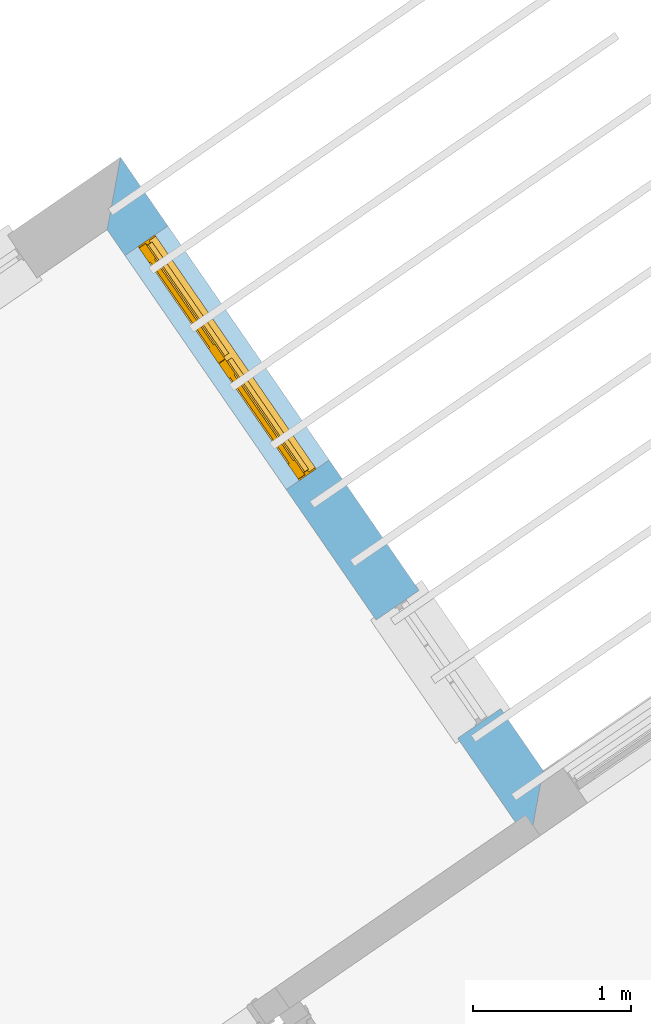
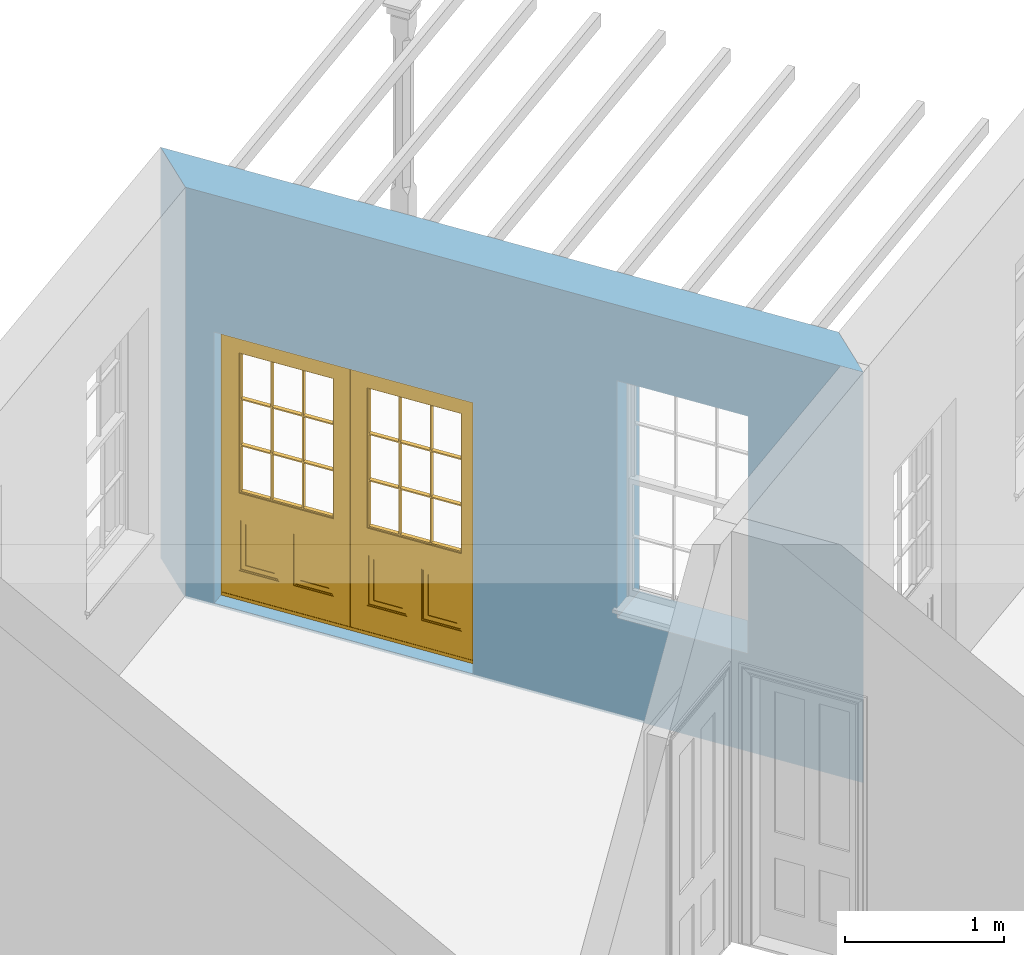
# One storey, part 8 of 12: 1 door, 2 openings, plus 1 element that does not belong to this part.
"""IFC2X3 building model written with IfcOpenShell, lengths in metres."""

from ifc_helpers import new_model, si_unit, frame, origin, place, context, subcontext, project, spatial, polyline, outline, extrude, faceted_brep, material, layer, layer_set, layer_usage, element, fill, save


model = new_model("IFC2X3")

# Units and contexts
model_context = context("Model", 3, world=origin())
body_context = subcontext(model_context, "Body", "Model", "MODEL_VIEW")
ifc_project = project(units=[si_unit("PLANEANGLEUNIT", "RADIAN"), si_unit("MASSUNIT", "GRAM", prefix="KILO"), si_unit("FORCEUNIT", "NEWTON", prefix="KILO"), si_unit("LENGTHUNIT", "METRE")], contexts=[model_context])

# Site, building, storey
site_placement = place(None, origin())
site = spatial("IfcSite", under=ifc_project, at=site_placement, CompositionType="ELEMENT")
building_placement = place(None, origin())
building = spatial("IfcBuilding", under=site, at=building_placement, Name="Building plot-7", CompositionType="ELEMENT")
storey_placement = place(None, frame((0.0, 0.0, 8.0)))
storey = spatial("IfcBuildingStorey", under=building, at=storey_placement, Name="Floor 1", CompositionType="ELEMENT", Elevation=8.0)

# Wall, openings, door
ifc_material = material(Name="Masonry")
ifc_layer = layer(ifc_material, 0.33, ventilated=False)
ifc_layer_set = layer_set([ifc_layer], Name="My Wall")
ifc_layer_usage = layer_usage(ifc_layer_set, "AXIS2", "NEGATIVE", 0.08)
wall_placement = place(storey_placement, origin())
wall = element("IfcWallStandardCase", 1, at=wall_placement, inside=storey, material=ifc_layer_usage, Name="exterior", context=body_context, shape_type="SweptSolid", body=[
    extrude(outline(polyline([(88.1099803913297, 67.5367543573869), (88.1944908209502, 67.9957292883857), (85.5190596071891, 71.8787614387522), (85.4345491775686, 71.4197865077534), (88.1099803913297, 67.5367543573869)])), origin(), (0.0, 0.0, 1.0), 3.15),
])
opening_1_placement = place(storey_placement, frame((0.0, 0.0, 0.75)))
element("IfcOpeningElement", 2, at=opening_1_placement, cuts=wall, Name="Opening", ObjectType="Opening", context=body_context, shape_type="SweptSolid", body=[
    extrude(outline(polyline([(87.9256291894368, 68.3859461453158), (87.4093220739, 69.1352971728363), (87.1375793935903, 68.9480649221472), (87.6538865091271, 68.1987138946266), (87.9256291894368, 68.3859461453158)])), origin(), (0.0, 0.0, 1.0), 1.82),
])
opening_2_placement = place(storey_placement, frame((0.0, 0.0, 0.0199999999999996)))
opening_2 = element("IfcOpeningElement", 3, at=opening_2_placement, cuts=wall, Name="Opening", ObjectType="Opening", context=body_context, shape_type="SweptSolid", body=[
    extrude(outline(polyline([(86.8403934357583, 69.9610213334149), (85.8191266138174, 71.4432541351038), (85.5473839335077, 71.2560218844146), (86.5686507554486, 69.7737890827257), (86.8403934357583, 69.9610213334149)])), origin(), (0.0, 0.0, 1.0), 2.08),
])
door_placement = place(storey_placement, frame((86.634527768857, 69.8191787192564, 0.0199999999999996), z_axis=(0.0, 0.0, 1.0), x_axis=(-1.02126682194091, 1.48223280168895, 0.0)))
door = element("IfcDoor", 4, at=door_placement, inside=storey, Name="living outside door", OverallHeight=2.08, OverallWidth=1.8, context=body_context, shape_type="Brep", held_by="IfcProductRepresentation", body=[
    faceted_brep([(0.545, -0.055, 0.265), (0.745, -0.055, 0.265), (0.745, -0.05, 0.265), (0.545, -0.05, 0.265), (0.745, -0.05, 0.58), (0.545, -0.05, 0.58), (0.545, -0.055, 0.58), (0.515, -0.06, 0.235), (0.775, -0.06, 0.235), (0.745, -0.055, 0.58), (0.515, -0.06, 0.61), (0.515, -0.065, 0.235), (0.775, -0.065, 0.235), (0.775, -0.06, 0.61), (0.515, -0.065, 0.61), (0.785, -0.065, 0.225), (0.505, -0.065, 0.225), (0.775, -0.065, 0.61), (0.505, -0.065, 0.62), (0.785, -0.065, 0.62), (0.505, -0.07, 0.225), (0.785, -0.07, 0.225), (0.505, -0.07, 0.62), (0.785, -0.07, 0.62), (0.883, -0.07, 0.075), (0.898, -0.07, 0.075), (0.405, -0.07, 0.62), (0.405, -0.07, 0.225), (0.027, -0.07, 0.075), (0.785, -0.07, 0.82), (0.125, -0.07, 0.82), (0.405, -0.065, 0.62), (0.405, -0.065, 0.225), (0.898, -0.07, 2.068), (0.027, -0.08, 0.075), (0.883, -0.08, 0.075), (0.125, -0.07, 0.225), (0.012, -0.07, 0.075), (0.785, -0.06, 0.82), (0.125, -0.06, 0.82), (0.125, -0.07, 0.62), (0.125, -0.065, 0.62), (0.395, -0.065, 0.61), (0.395, -0.065, 0.235), (0.125, -0.065, 0.225), (0.785, -0.07, 1.895), (0.027, -0.11, 0.045), (0.883, -0.11, 0.045), (0.558333, -0.06, 0.83), (0.351667, -0.06, 0.83), (0.125, -0.07, 1.895), (0.125, -0.06, 1.895), (0.785, -0.06, 1.895), (0.012, -0.07, 2.068), (0.135, -0.065, 0.61), (0.395, -0.06, 0.61), (0.395, -0.06, 0.235), (0.135, -0.065, 0.235), (0.027, -0.11, 0.027), (0.883, -0.11, 0.027), (0.568333, -0.06, 0.83), (0.558333, -0.03, 0.83), (0.351667, -0.03, 0.83), (0.341667, -0.06, 0.83), (0.135, -0.06, 1.185), (0.135, -0.06, 1.53), (0.775, -0.06, 1.53), (0.775, -0.06, 1.185), (0.135, -0.06, 0.61), (0.365, -0.055, 0.58), (0.365, -0.055, 0.265), (0.135, -0.06, 0.235), (0.568333, -0.06, 1.175), (0.558333, -0.06, 1.175), (0.775, -0.06, 0.83), (0.558333, -0.03, 1.175), (0.785, -0.03, 0.82), (0.125, -0.03, 0.82), (0.351667, -0.03, 1.175), (0.351667, -0.06, 1.175), (0.341667, -0.06, 1.175), (0.135, -0.06, 0.83), (0.135, -0.06, 1.175), (0.135, -0.03, 1.185), (0.135, -0.03, 1.53), (0.135, -0.06, 1.54), (0.351667, -0.06, 1.885), (0.558333, -0.06, 1.885), (0.775, -0.03, 1.53), (0.775, -0.03, 1.185), (0.775, -0.06, 1.175), (0.775, -0.06, 1.54), (0.165, -0.055, 0.58), (0.365, -0.05, 0.58), (0.365, -0.05, 0.265), (0.165, -0.055, 0.265), (0.568333, -0.03, 0.83), (0.568333, -0.03, 1.175), (0.568333, -0.06, 1.185), (0.558333, -0.06, 1.185), (0.775, -0.03, 0.83), (0.785, -0.02, 0.82), (0.125, -0.02, 0.82), (0.341667, -0.03, 0.83), (0.341667, -0.03, 1.175), (0.351667, -0.06, 1.185), (0.341667, -0.06, 1.185), (0.135, -0.03, 0.83), (0.341667, -0.03, 1.185), (0.125, -0.03, 1.895), (0.341667, -0.03, 1.53), (0.341667, -0.06, 1.53), (0.135, -0.06, 1.885), (0.341667, -0.06, 1.54), (0.341667, -0.06, 1.885), (0.558333, -0.03, 1.885), (0.351667, -0.03, 1.885), (0.568333, -0.06, 1.885), (0.785, -0.03, 1.895), (0.568333, -0.03, 1.185), (0.568333, -0.06, 1.53), (0.568333, -0.03, 1.53), (0.568333, -0.06, 1.54), (0.775, -0.06, 1.885), (0.165, -0.05, 0.58), (0.165, -0.05, 0.265), (0.775, -0.03, 1.175), (0.558333, -0.06, 1.53), (0.351667, -0.03, 1.185), (0.558333, -0.03, 1.185), (0.505, -0.02, 0.62), (0.405, -0.02, 0.62), (0.125, -0.02, 1.895), (0.785, -0.02, 1.895), (0.351667, -0.06, 1.53), (0.135, -0.03, 1.175), (0.135, -0.03, 1.54), (0.341667, -0.03, 1.54), (0.135, -0.03, 1.885), (0.351667, -0.06, 1.54), (0.558333, -0.03, 1.54), (0.558333, -0.06, 1.54), (0.351667, -0.03, 1.54), (0.775, -0.03, 1.54), (0.568333, -0.03, 1.54), (0.775, -0.03, 1.885), (0.558333, -0.03, 1.53), (0.405, -0.02, 0.225), (0.505, -0.02, 0.225), (0.125, -0.02, 0.62), (0.785, -0.02, 0.62), (0.012, -0.02, 2.068), (0.898, -0.02, 2.068), (0.351667, -0.03, 1.53), (0.341667, -0.03, 1.885), (0.568333, -0.03, 1.885), (0.405, -0.025, 0.225), (0.405, -0.025, 0.62), (0.505, -0.025, 0.62), (0.505, -0.025, 0.225), (0.898, -0.02, 0.027), (0.012, -0.02, 0.027), (0.125, -0.025, 0.62), (0.785, -0.025, 0.62), (0.395, -0.025, 0.235), (0.395, -0.025, 0.61), (0.125, -0.02, 0.225), (0.125, -0.025, 0.225), (0.515, -0.025, 0.61), (0.515, -0.025, 0.235), (0.785, -0.02, 0.225), (0.785, -0.025, 0.225), (0.135, -0.025, 0.61), (0.775, -0.025, 0.61), (0.135, -0.025, 0.235), (0.395, -0.03, 0.235), (0.395, -0.03, 0.61), (0.515, -0.03, 0.61), (0.515, -0.03, 0.235), (0.775, -0.025, 0.235), (0.135, -0.03, 0.61), (0.775, -0.03, 0.61), (0.135, -0.03, 0.235), (0.365, -0.035, 0.265), (0.365, -0.035, 0.58), (0.545, -0.035, 0.58), (0.545, -0.035, 0.265), (0.775, -0.03, 0.235), (0.165, -0.035, 0.58), (0.745, -0.035, 0.58), (0.165, -0.035, 0.265), (0.365, -0.04, 0.58), (0.365, -0.04, 0.265), (0.545, -0.04, 0.58), (0.545, -0.04, 0.265), (0.745, -0.035, 0.265), (0.165, -0.04, 0.58), (0.745, -0.04, 0.58), (0.165, -0.04, 0.265), (0.745, -0.04, 0.265), (1.775, -0.072, 0.025), (0.025, -0.072, 0.025), (0.025, -0.1, 0.025), (1.775, -0.1, 0.025), (1.79, -0.02, 0.025), (0.01, -0.02, 0.025), (1.79, -0.072, 0.025), (1.8, -0.02, 0.0), (0.0, -0.02, 0.0), (0.01, -0.072, 0.025), (1.79, -0.072, 2.07), (1.79, -0.02, 2.07), (1.775, -0.072, 2.055), (1.8, -0.02, 2.08), (0.01, -0.02, 2.07), (0.0, -0.02, 2.08), (0.01, -0.072, 2.07), (0.025, -0.072, 2.055), (0.0, -0.15, 2.08), (1.8, -0.15, 2.08), (0.01, -0.15, 2.07), (1.79, -0.15, 2.07), (0.01, -0.1, 2.07), (1.79, -0.1, 2.07), (0.0, -0.15, 0.0), (1.8, -0.15, 0.0), (0.01, -0.15, 0.025), (1.79, -0.15, 0.025), (0.01, -0.1, 0.025), (0.025, -0.1, 2.055), (1.79, -0.1, 0.025), (1.775, -0.1, 2.055), (0.898, -0.07, 0.027), (0.012, -0.07, 0.027), (0.883, -0.07, 0.027), (0.027, -0.07, 0.027), (1.435, -0.055, 0.265), (1.635, -0.055, 0.265), (1.635, -0.05, 0.265), (1.435, -0.05, 0.265), (1.635, -0.05, 0.58), (1.435, -0.05, 0.58), (1.435, -0.055, 0.58), (1.405, -0.06, 0.235), (1.665, -0.06, 0.235), (1.635, -0.055, 0.58), (1.405, -0.06, 0.61), (1.405, -0.065, 0.235), (1.665, -0.065, 0.235), (1.665, -0.06, 0.61), (1.405, -0.065, 0.61), (1.675, -0.065, 0.225), (1.395, -0.065, 0.225), (1.665, -0.065, 0.61), (1.395, -0.065, 0.62), (1.675, -0.065, 0.62), (1.395, -0.07, 0.225), (1.675, -0.07, 0.225), (1.395, -0.07, 0.62), (1.675, -0.07, 0.62), (1.773, -0.07, 0.075), (1.788, -0.07, 0.075), (1.295, -0.07, 0.62), (1.295, -0.07, 0.225), (0.917, -0.07, 0.075), (1.675, -0.07, 0.82), (1.015, -0.07, 0.82), (1.295, -0.065, 0.62), (1.295, -0.065, 0.225), (1.788, -0.07, 2.068), (0.917, -0.08, 0.075), (1.773, -0.08, 0.075), (1.015, -0.07, 0.225), (0.902, -0.07, 0.075), (1.675, -0.06, 0.82), (1.015, -0.06, 0.82), (1.015, -0.07, 0.62), (1.015, -0.065, 0.62), (1.285, -0.065, 0.61), (1.285, -0.065, 0.235), (1.015, -0.065, 0.225), (1.675, -0.07, 1.895), (0.917, -0.11, 0.045), (1.773, -0.11, 0.045), (1.448333, -0.06, 0.83), (1.241667, -0.06, 0.83), (1.015, -0.07, 1.895), (1.015, -0.06, 1.895), (1.675, -0.06, 1.895), (0.902, -0.07, 2.068), (1.025, -0.065, 0.61), (1.285, -0.06, 0.61), (1.285, -0.06, 0.235), (1.025, -0.065, 0.235), (0.917, -0.11, 0.027), (1.773, -0.11, 0.027), (1.458333, -0.06, 0.83), (1.448333, -0.03, 0.83), (1.241667, -0.03, 0.83), (1.231667, -0.06, 0.83), (1.025, -0.06, 1.185), (1.025, -0.06, 1.53), (1.665, -0.06, 1.53), (1.665, -0.06, 1.185), (1.025, -0.06, 0.61), (1.255, -0.055, 0.58), (1.255, -0.055, 0.265), (1.025, -0.06, 0.235), (1.458333, -0.06, 1.175), (1.448333, -0.06, 1.175), (1.665, -0.06, 0.83), (1.448333, -0.03, 1.175), (1.675, -0.03, 0.82), (1.015, -0.03, 0.82), (1.241667, -0.03, 1.175), (1.241667, -0.06, 1.175), (1.231667, -0.06, 1.175), (1.025, -0.06, 0.83), (1.025, -0.06, 1.175), (1.025, -0.03, 1.185), (1.025, -0.03, 1.53), (1.025, -0.06, 1.54), (1.241667, -0.06, 1.885), (1.448333, -0.06, 1.885), (1.665, -0.03, 1.53), (1.665, -0.03, 1.185), (1.665, -0.06, 1.175), (1.665, -0.06, 1.54), (1.055, -0.055, 0.58), (1.255, -0.05, 0.58), (1.255, -0.05, 0.265), (1.055, -0.055, 0.265), (1.458333, -0.03, 0.83), (1.458333, -0.03, 1.175), (1.458333, -0.06, 1.185), (1.448333, -0.06, 1.185), (1.665, -0.03, 0.83), (1.675, -0.02, 0.82), (1.015, -0.02, 0.82), (1.231667, -0.03, 0.83), (1.231667, -0.03, 1.175), (1.241667, -0.06, 1.185), (1.231667, -0.06, 1.185), (1.025, -0.03, 0.83), (1.231667, -0.03, 1.185), (1.015, -0.03, 1.895), (1.231667, -0.03, 1.53), (1.231667, -0.06, 1.53), (1.025, -0.06, 1.885), (1.231667, -0.06, 1.54), (1.231667, -0.06, 1.885), (1.448333, -0.03, 1.885), (1.241667, -0.03, 1.885), (1.458333, -0.06, 1.885), (1.675, -0.03, 1.895), (1.458333, -0.03, 1.185), (1.458333, -0.06, 1.53), (1.458333, -0.03, 1.53), (1.458333, -0.06, 1.54), (1.665, -0.06, 1.885), (1.055, -0.05, 0.58), (1.055, -0.05, 0.265), (1.665, -0.03, 1.175), (1.448333, -0.06, 1.53), (1.241667, -0.03, 1.185), (1.448333, -0.03, 1.185), (1.395, -0.02, 0.62), (1.295, -0.02, 0.62), (1.015, -0.02, 1.895), (1.675, -0.02, 1.895), (1.241667, -0.06, 1.53), (1.025, -0.03, 1.175), (1.025, -0.03, 1.54), (1.231667, -0.03, 1.54), (1.025, -0.03, 1.885), (1.241667, -0.06, 1.54), (1.448333, -0.03, 1.54), (1.448333, -0.06, 1.54), (1.241667, -0.03, 1.54), (1.665, -0.03, 1.54), (1.458333, -0.03, 1.54), (1.665, -0.03, 1.885), (1.448333, -0.03, 1.53), (1.295, -0.02, 0.225), (1.395, -0.02, 0.225), (1.015, -0.02, 0.62), (1.675, -0.02, 0.62), (0.902, -0.02, 2.068), (1.788, -0.02, 2.068), (1.241667, -0.03, 1.53), (1.231667, -0.03, 1.885), (1.458333, -0.03, 1.885), (1.295, -0.025, 0.225), (1.295, -0.025, 0.62), (1.395, -0.025, 0.62), (1.395, -0.025, 0.225), (1.788, -0.02, 0.027), (0.902, -0.02, 0.027), (1.015, -0.025, 0.62), (1.675, -0.025, 0.62), (1.285, -0.025, 0.235), (1.285, -0.025, 0.61), (1.015, -0.02, 0.225), (1.015, -0.025, 0.225), (1.405, -0.025, 0.61), (1.405, -0.025, 0.235), (1.675, -0.02, 0.225), (1.675, -0.025, 0.225), (1.025, -0.025, 0.61), (1.665, -0.025, 0.61), (1.025, -0.025, 0.235), (1.285, -0.03, 0.235), (1.285, -0.03, 0.61), (1.405, -0.03, 0.61), (1.405, -0.03, 0.235), (1.665, -0.025, 0.235), (1.025, -0.03, 0.61), (1.665, -0.03, 0.61), (1.025, -0.03, 0.235), (1.255, -0.035, 0.265), (1.255, -0.035, 0.58), (1.435, -0.035, 0.58), (1.435, -0.035, 0.265), (1.665, -0.03, 0.235), (1.055, -0.035, 0.58), (1.635, -0.035, 0.58), (1.055, -0.035, 0.265), (1.255, -0.04, 0.58), (1.255, -0.04, 0.265), (1.435, -0.04, 0.58), (1.435, -0.04, 0.265), (1.635, -0.035, 0.265), (1.055, -0.04, 0.58), (1.635, -0.04, 0.58), (1.055, -0.04, 0.265), (1.635, -0.04, 0.265), (1.788, -0.07, 0.027), (0.902, -0.07, 0.027), (1.773, -0.07, 0.027), (0.917, -0.07, 0.027)], [[[0, 1, 2, 3]], [[2, 4, 5, 3]], [[0, 3, 5, 6]], [[1, 0, 7, 8]], [[9, 4, 2, 1]], [[9, 6, 5, 4]], [[0, 6, 10, 7]], [[8, 7, 11, 12]], [[8, 13, 9, 1]], [[13, 10, 6, 9]], [[7, 10, 14, 11]], [[15, 12, 11, 16]], [[12, 17, 13, 8]], [[17, 14, 10, 13]], [[18, 16, 11, 14]], [[15, 19, 17, 12]], [[15, 16, 20, 21]], [[14, 17, 19, 18]], [[16, 18, 22, 20]], [[21, 23, 19, 15]], [[24, 25, 21, 20]], [[23, 22, 18, 19]], [[20, 22, 26, 27]], [[23, 21, 25]], [[28, 24, 20, 27]], [[22, 23, 29]], [[29, 30, 26, 22]], [[27, 26, 31, 32]], [[23, 25, 33, 29]], [[34, 35, 24, 28]], [[28, 27, 36, 37]], [[38, 39, 30, 29]], [[26, 30, 40]], [[26, 40, 41, 31]], [[42, 43, 32, 31]], [[32, 44, 36, 27]], [[33, 45, 29]], [[46, 47, 35, 34]], [[36, 40, 37]], [[39, 38, 48, 49]], [[50, 30, 39, 51]], [[29, 45, 52, 38]], [[53, 37, 40, 30]], [[44, 41, 40, 36]], [[31, 41, 54, 42]], [[43, 42, 55, 56]], [[57, 44, 32, 43]], [[50, 45, 33, 53]], [[47, 46, 58, 59]], [[60, 48, 38]], [[49, 48, 61, 62]], [[49, 63, 39]], [[50, 53, 30]], [[51, 39, 64, 65]], [[45, 50, 51, 52]], [[66, 67, 38, 52]], [[57, 54, 41, 44]], [[42, 54, 68, 55]], [[56, 55, 69, 70]], [[56, 71, 57, 43]], [[60, 72, 73, 48]], [[60, 38, 74]], [[48, 73, 75, 61]], [[76, 77, 62, 61]], [[62, 78, 79, 49]], [[49, 79, 80, 63]], [[63, 81, 39]], [[82, 64, 39]], [[65, 64, 83, 84]], [[85, 51, 65]], [[52, 51, 86, 87]], [[88, 89, 67, 66]], [[90, 38, 67]], [[91, 66, 52]], [[71, 68, 54, 57]], [[55, 68, 92, 69]], [[69, 93, 94, 70]], [[70, 95, 71, 56]], [[96, 97, 72, 60]], [[73, 72, 98, 99]], [[74, 38, 90]], [[100, 96, 60, 74]], [[75, 73, 79, 78]], [[61, 75, 97, 96]], [[101, 102, 77, 76]], [[77, 103, 62]], [[96, 76, 61]], [[103, 104, 78, 62]], [[80, 79, 105, 106]], [[63, 80, 104, 103]], [[81, 63, 103, 107]], [[81, 82, 39]], [[106, 64, 82, 80]], [[106, 108, 83, 64]], [[84, 83, 77, 109]], [[110, 111, 65, 84]], [[112, 51, 85]], [[113, 85, 65, 111]], [[114, 86, 51]], [[115, 87, 86, 116]], [[117, 52, 87]], [[118, 76, 89, 88]], [[119, 98, 67, 89]], [[120, 121, 88, 66]], [[67, 98, 72, 90]], [[91, 122, 120, 66]], [[91, 52, 123]], [[95, 92, 68, 71]], [[69, 92, 124, 93]], [[94, 93, 124, 125]], [[94, 125, 95, 70]], [[72, 97, 126, 90]], [[127, 99, 98, 120]], [[99, 105, 79, 73]], [[74, 90, 126, 100]], [[96, 100, 76]], [[128, 129, 75, 78]], [[97, 75, 129, 119]], [[130, 131, 102, 101]], [[109, 77, 102, 132]], [[133, 101, 76, 118]], [[77, 107, 103]], [[78, 104, 108, 128]], [[111, 106, 105, 134]], [[104, 80, 82, 135]], [[107, 135, 82, 81]], [[110, 108, 106, 111]], [[104, 135, 83, 108]], [[83, 135, 77]], [[136, 84, 109]], [[110, 84, 136, 137]], [[114, 51, 112]], [[85, 136, 138, 112]], [[113, 137, 136, 85]], [[111, 134, 139, 113]], [[86, 114, 113, 139]], [[140, 141, 87, 115]], [[139, 142, 116, 86]], [[109, 118, 115, 116]], [[117, 123, 52]], [[117, 87, 141, 122]], [[126, 89, 76]], [[143, 118, 88]], [[120, 98, 119, 121]], [[119, 89, 126, 97]], [[144, 143, 88, 121]], [[144, 122, 91, 143]], [[127, 120, 122, 141]], [[143, 91, 123, 145]], [[124, 92, 95, 125]], [[146, 129, 99, 127]], [[99, 129, 128, 105]], [[100, 126, 76]], [[121, 119, 129, 146]], [[147, 131, 130, 148]], [[131, 149, 102]], [[130, 101, 150]], [[102, 151, 132]], [[118, 109, 132, 133]], [[101, 133, 152]], [[107, 77, 135]], [[153, 128, 108, 110]], [[134, 105, 128, 153]], [[109, 138, 136]], [[153, 110, 137, 142]], [[154, 114, 112, 138]], [[137, 113, 114, 154]], [[141, 139, 134, 127]], [[141, 140, 142, 139]], [[144, 140, 115, 155]], [[142, 137, 154, 116]], [[155, 115, 118]], [[116, 154, 109]], [[117, 155, 145, 123]], [[122, 144, 155, 117]], [[143, 145, 118]], [[121, 146, 140, 144]], [[146, 127, 134, 153]], [[156, 157, 131, 147]], [[148, 130, 158, 159]], [[148, 160, 161, 147]], [[157, 162, 149, 131]], [[161, 151, 102, 149]], [[101, 152, 160, 150]], [[163, 158, 130, 150]], [[151, 152, 133, 132]], [[154, 138, 109]], [[142, 140, 146, 153]], [[145, 155, 118]], [[157, 156, 164, 165]], [[147, 166, 167, 156]], [[168, 169, 159, 158]], [[170, 148, 159, 171]], [[148, 170, 160]], [[166, 147, 161]], [[172, 162, 157, 165]], [[166, 149, 162, 167]], [[166, 161, 149]], [[150, 160, 170]], [[163, 173, 168, 158]], [[171, 163, 150, 170]], [[174, 164, 156, 167]], [[175, 176, 165, 164]], [[169, 168, 177, 178]], [[171, 159, 169, 179]], [[167, 162, 172, 174]], [[176, 180, 172, 165]], [[179, 173, 163, 171]], [[181, 177, 168, 173]], [[164, 174, 182, 175]], [[183, 184, 176, 175]], [[178, 177, 185, 186]], [[179, 169, 178, 187]], [[174, 172, 180, 182]], [[184, 188, 180, 176]], [[187, 181, 173, 179]], [[189, 185, 177, 181]], [[175, 182, 190, 183]], [[191, 184, 183, 192]], [[185, 193, 194, 186]], [[187, 178, 186, 195]], [[182, 180, 188, 190]], [[191, 196, 188, 184]], [[195, 189, 181, 187]], [[197, 193, 185, 189]], [[183, 190, 198, 192]], [[198, 196, 191, 192]], [[194, 193, 197, 199]], [[195, 186, 194, 199]], [[188, 196, 198, 190]], [[197, 189, 195, 199]], [[200, 201, 202, 203]], [[201, 200, 204, 205]], [[206, 204, 200]], [[204, 207, 208, 205]], [[209, 201, 205]], [[210, 211, 204, 206]], [[206, 200, 212, 210]], [[211, 213, 207, 204]], [[214, 205, 208, 215]], [[216, 217, 201, 209]], [[205, 214, 216, 209]], [[216, 214, 211, 210]], [[210, 212, 217, 216]], [[214, 215, 213, 211]], [[218, 219, 213, 215]], [[219, 218, 220, 221]], [[221, 220, 222, 223]], [[215, 208, 224, 218]], [[225, 224, 208, 207]], [[224, 226, 220, 218]], [[224, 225, 227, 226]], [[219, 225, 207, 213]], [[228, 222, 220, 226]], [[219, 221, 227, 225]], [[226, 227, 203, 202]], [[202, 229, 222, 228]], [[228, 226, 202]], [[227, 221, 223, 230]], [[230, 203, 227]], [[217, 229, 202, 201]], [[231, 223, 222, 229]], [[230, 223, 231, 203]], [[231, 229, 217, 212]], [[212, 200, 203, 231]], [[33, 152, 151, 53]], [[25, 160, 152, 33]], [[161, 37, 53, 151]], [[232, 160, 25]], [[161, 233, 37]], [[160, 232, 234]], [[24, 234, 232, 25]], [[233, 161, 235]], [[37, 233, 235, 28]], [[161, 160, 234, 235]], [[35, 47, 234, 24]], [[28, 235, 46, 34]], [[58, 235, 234, 59]], [[59, 234, 47]], [[58, 46, 235]], [[236, 237, 238, 239]], [[238, 240, 241, 239]], [[236, 239, 241, 242]], [[237, 236, 243, 244]], [[245, 240, 238, 237]], [[245, 242, 241, 240]], [[236, 242, 246, 243]], [[244, 243, 247, 248]], [[244, 249, 245, 237]], [[249, 246, 242, 245]], [[243, 246, 250, 247]], [[251, 248, 247, 252]], [[248, 253, 249, 244]], [[253, 250, 246, 249]], [[254, 252, 247, 250]], [[251, 255, 253, 248]], [[251, 252, 256, 257]], [[250, 253, 255, 254]], [[252, 254, 258, 256]], [[257, 259, 255, 251]], [[260, 261, 257, 256]], [[259, 258, 254, 255]], [[256, 258, 262, 263]], [[259, 257, 261]], [[264, 260, 256, 263]], [[258, 259, 265]], [[265, 266, 262, 258]], [[263, 262, 267, 268]], [[259, 261, 269, 265]], [[270, 271, 260, 264]], [[264, 263, 272, 273]], [[274, 275, 266, 265]], [[262, 266, 276]], [[262, 276, 277, 267]], [[278, 279, 268, 267]], [[268, 280, 272, 263]], [[269, 281, 265]], [[282, 283, 271, 270]], [[272, 276, 273]], [[275, 274, 284, 285]], [[286, 266, 275, 287]], [[265, 281, 288, 274]], [[289, 273, 276, 266]], [[280, 277, 276, 272]], [[267, 277, 290, 278]], [[279, 278, 291, 292]], [[293, 280, 268, 279]], [[286, 281, 269, 289]], [[283, 282, 294, 295]], [[296, 284, 274]], [[285, 284, 297, 298]], [[285, 299, 275]], [[286, 289, 266]], [[287, 275, 300, 301]], [[281, 286, 287, 288]], [[302, 303, 274, 288]], [[293, 290, 277, 280]], [[278, 290, 304, 291]], [[292, 291, 305, 306]], [[292, 307, 293, 279]], [[296, 308, 309, 284]], [[296, 274, 310]], [[284, 309, 311, 297]], [[312, 313, 298, 297]], [[298, 314, 315, 285]], [[285, 315, 316, 299]], [[299, 317, 275]], [[318, 300, 275]], [[301, 300, 319, 320]], [[321, 287, 301]], [[288, 287, 322, 323]], [[324, 325, 303, 302]], [[326, 274, 303]], [[327, 302, 288]], [[307, 304, 290, 293]], [[291, 304, 328, 305]], [[305, 329, 330, 306]], [[306, 331, 307, 292]], [[332, 333, 308, 296]], [[309, 308, 334, 335]], [[310, 274, 326]], [[336, 332, 296, 310]], [[311, 309, 315, 314]], [[297, 311, 333, 332]], [[337, 338, 313, 312]], [[313, 339, 298]], [[332, 312, 297]], [[339, 340, 314, 298]], [[316, 315, 341, 342]], [[299, 316, 340, 339]], [[317, 299, 339, 343]], [[317, 318, 275]], [[342, 300, 318, 316]], [[342, 344, 319, 300]], [[320, 319, 313, 345]], [[346, 347, 301, 320]], [[348, 287, 321]], [[349, 321, 301, 347]], [[350, 322, 287]], [[351, 323, 322, 352]], [[353, 288, 323]], [[354, 312, 325, 324]], [[355, 334, 303, 325]], [[356, 357, 324, 302]], [[303, 334, 308, 326]], [[327, 358, 356, 302]], [[327, 288, 359]], [[331, 328, 304, 307]], [[305, 328, 360, 329]], [[330, 329, 360, 361]], [[330, 361, 331, 306]], [[308, 333, 362, 326]], [[363, 335, 334, 356]], [[335, 341, 315, 309]], [[310, 326, 362, 336]], [[332, 336, 312]], [[364, 365, 311, 314]], [[333, 311, 365, 355]], [[366, 367, 338, 337]], [[345, 313, 338, 368]], [[369, 337, 312, 354]], [[313, 343, 339]], [[314, 340, 344, 364]], [[347, 342, 341, 370]], [[340, 316, 318, 371]], [[343, 371, 318, 317]], [[346, 344, 342, 347]], [[340, 371, 319, 344]], [[319, 371, 313]], [[372, 320, 345]], [[346, 320, 372, 373]], [[350, 287, 348]], [[321, 372, 374, 348]], [[349, 373, 372, 321]], [[347, 370, 375, 349]], [[322, 350, 349, 375]], [[376, 377, 323, 351]], [[375, 378, 352, 322]], [[345, 354, 351, 352]], [[353, 359, 288]], [[353, 323, 377, 358]], [[362, 325, 312]], [[379, 354, 324]], [[356, 334, 355, 357]], [[355, 325, 362, 333]], [[380, 379, 324, 357]], [[380, 358, 327, 379]], [[363, 356, 358, 377]], [[379, 327, 359, 381]], [[360, 328, 331, 361]], [[382, 365, 335, 363]], [[335, 365, 364, 341]], [[336, 362, 312]], [[357, 355, 365, 382]], [[383, 367, 366, 384]], [[367, 385, 338]], [[366, 337, 386]], [[338, 387, 368]], [[354, 345, 368, 369]], [[337, 369, 388]], [[343, 313, 371]], [[389, 364, 344, 346]], [[370, 341, 364, 389]], [[345, 374, 372]], [[389, 346, 373, 378]], [[390, 350, 348, 374]], [[373, 349, 350, 390]], [[377, 375, 370, 363]], [[377, 376, 378, 375]], [[380, 376, 351, 391]], [[378, 373, 390, 352]], [[391, 351, 354]], [[352, 390, 345]], [[353, 391, 381, 359]], [[358, 380, 391, 353]], [[379, 381, 354]], [[357, 382, 376, 380]], [[382, 363, 370, 389]], [[392, 393, 367, 383]], [[384, 366, 394, 395]], [[384, 396, 397, 383]], [[393, 398, 385, 367]], [[397, 387, 338, 385]], [[337, 388, 396, 386]], [[399, 394, 366, 386]], [[387, 388, 369, 368]], [[390, 374, 345]], [[378, 376, 382, 389]], [[381, 391, 354]], [[393, 392, 400, 401]], [[383, 402, 403, 392]], [[404, 405, 395, 394]], [[406, 384, 395, 407]], [[384, 406, 396]], [[402, 383, 397]], [[408, 398, 393, 401]], [[402, 385, 398, 403]], [[402, 397, 385]], [[386, 396, 406]], [[399, 409, 404, 394]], [[407, 399, 386, 406]], [[410, 400, 392, 403]], [[411, 412, 401, 400]], [[405, 404, 413, 414]], [[407, 395, 405, 415]], [[403, 398, 408, 410]], [[412, 416, 408, 401]], [[415, 409, 399, 407]], [[417, 413, 404, 409]], [[400, 410, 418, 411]], [[419, 420, 412, 411]], [[414, 413, 421, 422]], [[415, 405, 414, 423]], [[410, 408, 416, 418]], [[420, 424, 416, 412]], [[423, 417, 409, 415]], [[425, 421, 413, 417]], [[411, 418, 426, 419]], [[427, 420, 419, 428]], [[421, 429, 430, 422]], [[423, 414, 422, 431]], [[418, 416, 424, 426]], [[427, 432, 424, 420]], [[431, 425, 417, 423]], [[433, 429, 421, 425]], [[419, 426, 434, 428]], [[434, 432, 427, 428]], [[430, 429, 433, 435]], [[431, 422, 430, 435]], [[424, 432, 434, 426]], [[433, 425, 431, 435]], [[269, 388, 387, 289]], [[261, 396, 388, 269]], [[397, 273, 289, 387]], [[436, 396, 261]], [[397, 437, 273]], [[396, 436, 438]], [[260, 438, 436, 261]], [[437, 397, 439]], [[273, 437, 439, 264]], [[397, 396, 438, 439]], [[271, 283, 438, 260]], [[264, 439, 282, 270]], [[294, 439, 438, 295]], [[295, 438, 283]], [[294, 282, 439]]]),
])
fill(opening_2, door)

save(model, "model.ifc")
